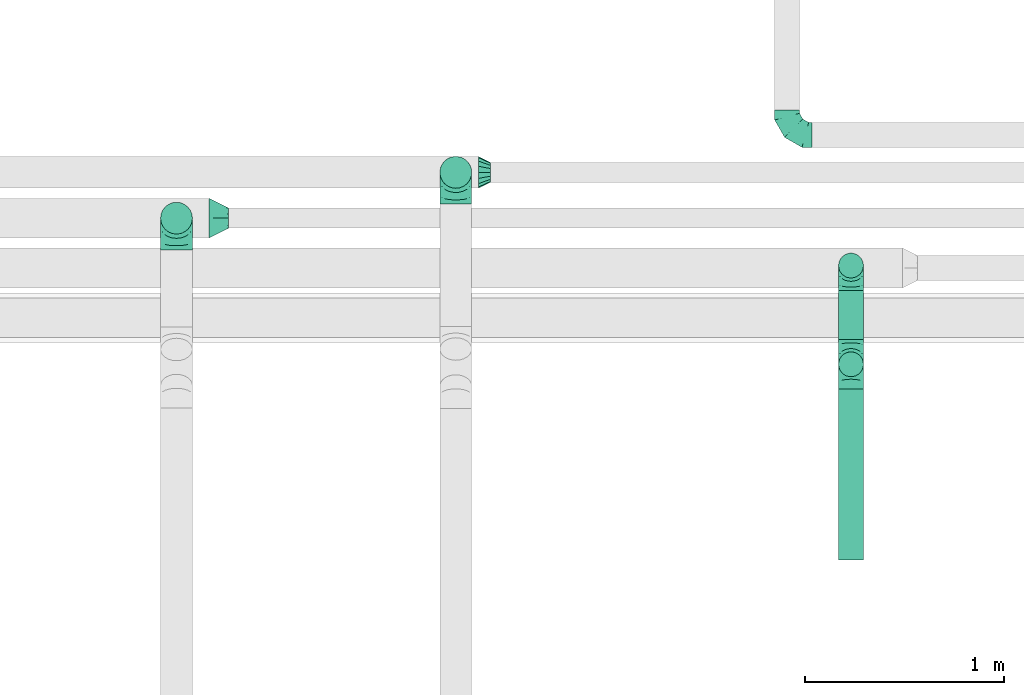
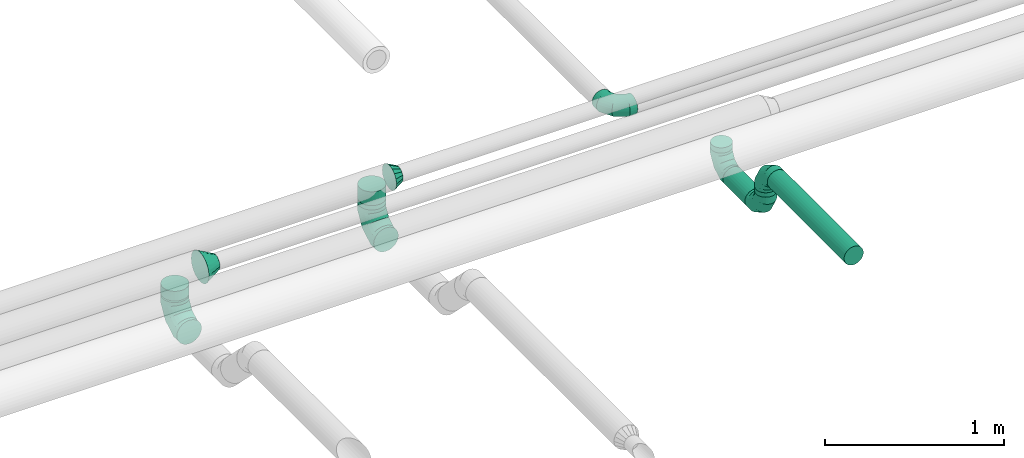
# One storey, part 52 of 92: 10 flow fittings, 5 flow segments.
"""IFC2X3 building model written with IfcOpenShell, lengths in millimetres."""

from ifc_helpers import new_model, entity, si_unit, converted_unit, derived_unit, direction, frame, origin, origin_2d_with_axis, place, context, subcontext, project, spatial, circle, extrude, faceted_brep, source, transform, mapped, material, type_object, type_shapes, element, save


model = new_model("IFC2X3")

# Units and contexts
model_context = context("Model", 3, precision=0.01, world=origin(), true_north=direction((6.12303176911189e-17, 1.0)))
body_context = subcontext(model_context, "Body", "Model", "MODEL_VIEW")
ifc_project = project(units=[si_unit("LENGTHUNIT", "METRE", prefix="MILLI"), si_unit("AREAUNIT", "SQUARE_METRE"), si_unit("VOLUMEUNIT", "CUBIC_METRE"), converted_unit("PLANEANGLEUNIT", "DEGREE", entity("IfcRatioMeasure", 0.0174532925199433), si_unit("PLANEANGLEUNIT", "RADIAN"), dimensions=[0, 0, 0, 0, 0, 0, 0]), si_unit("MASSUNIT", "GRAM", prefix="KILO"), derived_unit("MASSDENSITYUNIT", [(si_unit("MASSUNIT", "GRAM", prefix="KILO"), 1), (si_unit("LENGTHUNIT", "METRE"), -3)]), derived_unit("MOMENTOFINERTIAUNIT", [(si_unit("LENGTHUNIT", "METRE"), 4)]), si_unit("TIMEUNIT", "SECOND"), si_unit("FREQUENCYUNIT", "HERTZ"), si_unit("THERMODYNAMICTEMPERATUREUNIT", "DEGREE_CELSIUS"), derived_unit("THERMALTRANSMITTANCEUNIT", [(si_unit("MASSUNIT", "GRAM", prefix="KILO"), 1), (si_unit("THERMODYNAMICTEMPERATUREUNIT", "KELVIN"), -1), (si_unit("TIMEUNIT", "SECOND"), -3)]), derived_unit("VOLUMETRICFLOWRATEUNIT", [(si_unit("LENGTHUNIT", "METRE"), 3), (si_unit("TIMEUNIT", "SECOND"), -1)]), derived_unit("MASSFLOWRATEUNIT", [(si_unit("MASSUNIT", "GRAM", prefix="KILO"), 1), (si_unit("TIMEUNIT", "SECOND"), -1)]), derived_unit("ROTATIONALFREQUENCYUNIT", [(si_unit("TIMEUNIT", "SECOND"), -1)]), si_unit("ELECTRICCURRENTUNIT", "AMPERE"), si_unit("ELECTRICVOLTAGEUNIT", "VOLT"), si_unit("POWERUNIT", "WATT"), si_unit("FORCEUNIT", "NEWTON", prefix="KILO"), si_unit("ILLUMINANCEUNIT", "LUX"), si_unit("LUMINOUSFLUXUNIT", "LUMEN"), si_unit("LUMINOUSINTENSITYUNIT", "CANDELA"), derived_unit("USERDEFINED", [(si_unit("MASSUNIT", "GRAM", prefix="KILO"), -1), (si_unit("LENGTHUNIT", "METRE"), -2), (si_unit("TIMEUNIT", "SECOND"), 3), (si_unit("LUMINOUSFLUXUNIT", "LUMEN"), 1)]), derived_unit("LINEARVELOCITYUNIT", [(si_unit("LENGTHUNIT", "METRE"), 1), (si_unit("TIMEUNIT", "SECOND"), -1)]), si_unit("PRESSUREUNIT", "PASCAL"), derived_unit("USERDEFINED", [(si_unit("LENGTHUNIT", "METRE"), -2), (si_unit("MASSUNIT", "GRAM", prefix="KILO"), 1), (si_unit("TIMEUNIT", "SECOND"), -2)]), derived_unit("LINEARFORCEUNIT", [(si_unit("MASSUNIT", "GRAM", prefix="KILO"), 1), (si_unit("LENGTHUNIT", "METRE"), 1), (si_unit("TIMEUNIT", "SECOND"), -2), (si_unit("LENGTHUNIT", "METRE"), -1)]), derived_unit("PLANARFORCEUNIT", [(si_unit("MASSUNIT", "GRAM", prefix="KILO"), 1), (si_unit("LENGTHUNIT", "METRE"), 1), (si_unit("TIMEUNIT", "SECOND"), -2), (si_unit("LENGTHUNIT", "METRE"), -2)])], contexts=[model_context])

# Site, building, storey
site_placement = place(None, origin())
site = spatial("IfcSite", under=ifc_project, at=site_placement, CompositionType="ELEMENT")
building_placement = place(site_placement, origin())
building = spatial("IfcBuilding", under=site, at=building_placement, CompositionType="ELEMENT")
storey_placement = place(building_placement, frame((0.0, 0.0, 4200.0)))
storey = spatial("IfcBuildingStorey", under=building, at=storey_placement, CompositionType="ELEMENT", Elevation=4200.0)

# Flow segments
duct_segment_type = type_object("IfcDuctSegmentType", PredefinedType="NOTDEFINED")
flow_segment_1_placement = place(storey_placement, frame((44875.73, 4807.04, 3285.9)))
element("IfcFlowSegment", 1, at=flow_segment_1_placement, inside=storey, type_object=duct_segment_type, context=body_context, shape_type="SweptSolid", body=[
    extrude(circle(Radius=62.5, at=origin_2d_with_axis()), frame((64.1, 0.0, 64.1), z_axis=(0.0, 1.0, 0.0), x_axis=(-1.0, 0.0, 0.0)), (0.0, 0.0, 1.0), 858.438177938198),
])
flow_segment_2_placement = place(storey_placement, frame((42872.64, 6673.44, 3230.0)))
element("IfcFlowSegment", 2, at=flow_segment_2_placement, inside=storey, type_object=duct_segment_type, context=body_context, shape_type="SweptSolid", body=[
    extrude(circle(Radius=80.0, at=origin_2d_with_axis()), frame((81.6, 81.6, 0.0)), (0.0, 0.0, 1.0), 29.999999999991),
])
flow_segment_3_placement = place(storey_placement, frame((44875.73, 5915.48, 3005.9)))
element("IfcFlowSegment", 3, at=flow_segment_3_placement, inside=storey, type_object=duct_segment_type, context=body_context, shape_type="SweptSolid", body=[
    extrude(circle(Radius=62.5, at=origin_2d_with_axis()), frame((64.1, 0.0, 64.1), z_axis=(0.0, 1.0, 0.0), x_axis=(-1.0, 0.0, 0.0)), (0.0, 0.0, 1.0), 246.131881758027),
])
flow_segment_4_placement = place(storey_placement, frame((44875.73, 5726.39, 3195.0)))
element("IfcFlowSegment", 4, at=flow_segment_4_placement, inside=storey, type_object=duct_segment_type, context=body_context, shape_type="SweptSolid", body=[
    extrude(circle(Radius=62.5, at=origin_2d_with_axis()), frame((64.1, 64.1, 0.0)), (0.0, 0.0, 1.0), 30.000000000017),
])
flow_segment_5_placement = place(storey_placement, frame((44875.73, 6222.52, 3195.0)))
element("IfcFlowSegment", 5, at=flow_segment_5_placement, inside=storey, type_object=duct_segment_type, context=body_context, shape_type="SweptSolid", body=[
    extrude(circle(Radius=62.5, at=origin_2d_with_axis()), frame((64.1, 64.1, 0.0)), (0.0, 0.0, 1.0), 35.6986404926801),
])

# Flow fittings
ifc_material = material()
duct_fitting_type_1 = type_object("IfcDuctFittingType", PredefinedType="NOTDEFINED", material=ifc_material)
shared_shape_1 = source(origin(), body_context, "Body", "Brep", [
    faceted_brep([(-160.0, 0.0, -80.0), (-160.0, -20.71, -77.27), (-160.0, -40.0, -69.28), (-160.0, -56.57, -56.57), (-160.0, -69.28, -40.0), (-160.0, -77.27, -20.71), (-160.0, -80.0, 0.0), (-160.0, -77.27, 20.71), (-160.0, -69.28, 40.0), (-160.0, -56.57, 56.57), (-160.0, -40.0, 69.28), (-160.0, -20.71, 77.27), (-160.0, 0.0, 80.0), (-160.0, 20.71, 77.27), (-160.0, 40.0, 69.28), (-160.0, 56.57, 56.57), (-160.0, 69.28, 40.0), (-160.0, 77.27, 20.71), (-160.0, 80.0, 0.0), (-160.0, 77.27, -20.71), (-160.0, 69.28, -40.0), (-160.0, 56.57, -56.57), (-160.0, 40.0, -69.28), (-160.0, 20.71, -77.27), (-122.68, 20.71, 77.27), (-127.85, 40.0, 69.28), (-117.13, 0.0, 80.0), (-132.29, 56.57, 56.57), (-137.83, 77.27, 20.71), (-138.56, 80.0, 0.0), (-135.69, 69.28, 40.0), (-135.69, 69.28, -40.0), (-132.29, 56.57, -56.57), (-137.83, 77.27, -20.71), (-122.68, 20.71, -77.27), (-117.13, 0.0, -80.0), (-127.85, 40.0, -69.28), (-111.58, -20.71, -77.27), (-106.41, -40.0, -69.28), (-101.97, -56.57, -56.57), (-98.56, -69.28, -40.0), (-96.42, -77.27, -20.71), (-95.69, -80.0, 0.0), (-96.42, -77.27, 20.71), (-98.56, -69.28, 40.0), (-101.97, -56.57, 56.57), (-106.41, -40.0, 69.28), (-111.58, -20.71, 77.27), (-58.03, 58.03, 77.27), (-72.15, 72.15, 69.28), (-42.87, 42.87, 80.0), (-84.28, 84.28, 56.57), (-93.59, 93.59, 40.0), (-99.44, 99.44, 20.71), (-101.44, 101.44, 0.0), (-99.44, 99.44, -20.71), (-93.59, 93.59, -40.0), (-84.28, 84.28, -56.57), (-58.03, 58.03, -77.27), (-42.87, 42.87, -80.0), (-72.15, 72.15, -69.28), (-27.71, 27.71, -77.27), (-13.59, 13.59, -69.28), (-1.46, 1.46, -56.57), (7.85, -7.85, -40.0), (13.7, -13.7, -20.71), (15.69, -15.69, 0.0), (13.7, -13.7, 20.71), (7.85, -7.85, 40.0), (-1.46, 1.46, 56.57), (-13.59, 13.59, 69.28), (-27.71, 27.71, 77.27), (-20.71, 122.68, 77.27), (-40.0, 127.85, 69.28), (0.0, 117.13, 80.0), (-56.57, 132.29, 56.57), (-69.28, 135.69, 40.0), (-77.27, 137.83, 20.71), (-80.0, 138.56, 0.0), (-77.27, 137.83, -20.71), (-69.28, 135.69, -40.0), (-56.57, 132.29, -56.57), (-20.71, 122.68, -77.27), (0.0, 117.13, -80.0), (-40.0, 127.85, -69.28), (20.71, 111.58, -77.27), (40.0, 106.41, -69.28), (56.57, 101.97, -56.57), (69.28, 98.56, -40.0), (77.27, 96.42, -20.71), (80.0, 95.69, 0.0), (77.27, 96.42, 20.71), (69.28, 98.56, 40.0), (56.57, 101.97, 56.57), (40.0, 106.41, 69.28), (20.71, 111.58, 77.27), (-20.71, 160.0, -77.27), (-40.0, 160.0, -69.28), (-56.57, 160.0, -56.57), (-69.28, 160.0, -40.0), (-77.27, 160.0, -20.71), (-80.0, 160.0, 0.0), (-77.27, 160.0, 20.71), (-69.28, 160.0, 40.0), (-56.57, 160.0, 56.57), (-40.0, 160.0, 69.28), (-20.71, 160.0, 77.27), (0.0, 160.0, 80.0), (20.71, 160.0, 77.27), (40.0, 160.0, 69.28), (56.57, 160.0, 56.57), (69.28, 160.0, 40.0), (77.27, 160.0, 20.71), (80.0, 160.0, 0.0), (77.27, 160.0, -20.71), (69.28, 160.0, -40.0), (56.57, 160.0, -56.57), (40.0, 160.0, -69.28), (20.71, 160.0, -77.27), (0.0, 160.0, -80.0)], [[[0, 1, 2, 3, 4, 5, 6, 7, 8, 9, 10, 11, 12, 13, 14, 15, 16, 17, 18, 19, 20, 21, 22, 23]], [[24, 25, 14, 13]], [[26, 24, 13, 12]], [[14, 25, 27, 15]], [[28, 29, 18, 17]], [[30, 28, 17, 16]], [[15, 27, 30, 16]], [[20, 31, 32, 21]], [[33, 31, 20, 19]], [[18, 29, 33, 19]], [[34, 35, 0, 23]], [[36, 34, 23, 22]], [[32, 36, 22, 21]], [[1, 0, 35, 37]], [[2, 1, 37, 38]], [[3, 2, 38, 39]], [[5, 4, 40, 41]], [[6, 5, 41, 42]], [[39, 40, 4, 3]], [[6, 42, 43, 7]], [[7, 43, 44, 8]], [[8, 44, 45, 9]], [[9, 45, 46, 10]], [[10, 46, 47, 11]], [[26, 12, 11, 47]], [[48, 49, 25, 24]], [[50, 48, 24, 26]], [[27, 25, 49, 51]], [[52, 53, 28, 30]], [[51, 52, 30, 27]], [[29, 28, 53, 54]], [[55, 56, 31, 33]], [[54, 55, 33, 29]], [[32, 31, 56, 57]], [[58, 59, 35, 34]], [[60, 58, 34, 36]], [[57, 60, 36, 32]], [[37, 35, 59, 61]], [[38, 37, 61, 62]], [[39, 38, 62, 63]], [[41, 40, 64, 65]], [[42, 41, 65, 66]], [[63, 64, 40, 39]], [[43, 42, 66, 67]], [[44, 43, 67, 68]], [[68, 69, 45, 44]], [[46, 45, 69, 70]], [[47, 46, 70, 71]], [[26, 47, 71, 50]], [[72, 73, 49, 48]], [[74, 72, 48, 50]], [[51, 49, 73, 75]], [[76, 77, 53, 52]], [[75, 76, 52, 51]], [[54, 53, 77, 78]], [[79, 80, 56, 55]], [[78, 79, 55, 54]], [[57, 56, 80, 81]], [[82, 83, 59, 58]], [[84, 82, 58, 60]], [[81, 84, 60, 57]], [[61, 59, 83, 85]], [[62, 61, 85, 86]], [[63, 62, 86, 87]], [[65, 64, 88, 89]], [[66, 65, 89, 90]], [[87, 88, 64, 63]], [[67, 66, 90, 91]], [[68, 67, 91, 92]], [[92, 93, 69, 68]], [[70, 69, 93, 94]], [[71, 70, 94, 95]], [[50, 71, 95, 74]], [[96, 97, 98, 99, 100, 101, 102, 103, 104, 105, 106, 107, 108, 109, 110, 111, 112, 113, 114, 115, 116, 117, 118, 119]], [[72, 74, 107, 106]], [[73, 72, 106, 105]], [[75, 73, 105, 104]], [[77, 76, 103, 102]], [[78, 77, 102, 101]], [[75, 104, 103, 76]], [[78, 101, 100, 79]], [[79, 100, 99, 80]], [[80, 99, 98, 81]], [[84, 97, 96, 82]], [[82, 96, 119, 83]], [[84, 81, 98, 97]], [[118, 117, 86, 85]], [[119, 118, 85, 83]], [[116, 87, 86, 117]], [[88, 115, 114, 89]], [[89, 114, 113, 90]], [[115, 88, 87, 116]], [[112, 111, 92, 91]], [[113, 112, 91, 90]], [[111, 110, 93, 92]], [[95, 94, 109, 108]], [[74, 95, 108, 107]], [[110, 109, 94, 93]]]),
])
type_shapes(duct_fitting_type_1, [shared_shape_1])
for number, where, z_axis, x_axis in (
    (6, (41550.83, 6524.85, 3070.0), (-1.0, 0.0, 0.0), (0.0, 0.0, -1.0)),
    (7, (42954.24, 6755.04, 3070.0), (-1.0, 0.0, 0.0), (0.0, 0.0, -1.0)),
):
    element("IfcFlowFitting", number, at=place(storey_placement, frame(where, z_axis=z_axis, x_axis=x_axis)), inside=storey, type_object=duct_fitting_type_1, material=ifc_material, context=body_context, shape_type="MappedRepresentation", body=[
        mapped(shared_shape_1, transform((0.0, 0.0, 0.0), scale=1.0)),
    ])
duct_fitting_type_2 = type_object("IfcDuctFittingType", PredefinedType="NOTDEFINED", material=ifc_material)
shared_shape_2 = source(origin(), body_context, "Body", "Brep", [
    faceted_brep([(-125.0, 0.0, -62.5), (-125.0, -16.18, -60.37), (-125.0, -31.25, -54.13), (-125.0, -44.19, -44.19), (-125.0, -54.13, -31.25), (-125.0, -60.37, -16.18), (-125.0, -62.5, 0.0), (-125.0, -60.37, 16.18), (-125.0, -54.13, 31.25), (-125.0, -44.19, 44.19), (-125.0, -31.25, 54.13), (-125.0, -16.18, 60.37), (-125.0, 0.0, 62.5), (-125.0, 16.18, 60.37), (-125.0, 31.25, 54.13), (-125.0, 44.19, 44.19), (-125.0, 54.13, 31.25), (-125.0, 60.37, 16.18), (-125.0, 62.5, 0.0), (-125.0, 60.37, -16.18), (-125.0, 54.13, -31.25), (-125.0, 44.19, -44.19), (-125.0, 31.25, -54.13), (-125.0, 16.18, -60.37), (-95.84, 16.18, 60.37), (-99.88, 31.25, 54.13), (-91.51, 0.0, 62.5), (-103.35, 44.19, 44.19), (-107.68, 60.37, 16.18), (-108.25, 62.5, 0.0), (-106.01, 54.13, 31.25), (-106.01, 54.13, -31.25), (-103.35, 44.19, -44.19), (-107.68, 60.37, -16.18), (-95.84, 16.18, -60.37), (-91.51, 0.0, -62.5), (-99.88, 31.25, -54.13), (-87.17, -16.18, -60.37), (-83.13, -31.25, -54.13), (-79.66, -44.19, -44.19), (-77.0, -54.13, -31.25), (-75.33, -60.37, -16.18), (-74.76, -62.5, 0.0), (-75.33, -60.37, 16.18), (-77.0, -54.13, 31.25), (-79.66, -44.19, 44.19), (-83.13, -31.25, 54.13), (-87.17, -16.18, 60.37), (-45.34, 45.34, 60.37), (-56.37, 56.37, 54.13), (-33.49, 33.49, 62.5), (-65.85, 65.85, 44.19), (-73.12, 73.12, 31.25), (-77.69, 77.69, 16.18), (-79.25, 79.25, 0.0), (-77.69, 77.69, -16.18), (-73.12, 73.12, -31.25), (-65.85, 65.85, -44.19), (-45.34, 45.34, -60.37), (-33.49, 33.49, -62.5), (-56.37, 56.37, -54.13), (-21.65, 21.65, -60.37), (-10.62, 10.62, -54.13), (-1.14, 1.14, -44.19), (6.13, -6.13, -31.25), (10.7, -10.7, -16.18), (12.26, -12.26, 0.0), (10.7, -10.7, 16.18), (6.13, -6.13, 31.25), (-1.14, 1.14, 44.19), (-10.62, 10.62, 54.13), (-21.65, 21.65, 60.37), (-16.18, 95.84, 60.37), (-31.25, 99.88, 54.13), (0.0, 91.51, 62.5), (-44.19, 103.35, 44.19), (-54.13, 106.01, 31.25), (-60.37, 107.68, 16.18), (-62.5, 108.25, 0.0), (-60.37, 107.68, -16.18), (-54.13, 106.01, -31.25), (-44.19, 103.35, -44.19), (-16.18, 95.84, -60.37), (0.0, 91.51, -62.5), (-31.25, 99.88, -54.13), (16.18, 87.17, -60.37), (31.25, 83.13, -54.13), (44.19, 79.66, -44.19), (54.13, 77.0, -31.25), (60.37, 75.33, -16.18), (62.5, 74.76, 0.0), (60.37, 75.33, 16.18), (54.13, 77.0, 31.25), (44.19, 79.66, 44.19), (31.25, 83.13, 54.13), (16.18, 87.17, 60.37), (-16.18, 125.0, -60.37), (-31.25, 125.0, -54.13), (-44.19, 125.0, -44.19), (-54.13, 125.0, -31.25), (-60.37, 125.0, -16.18), (-62.5, 125.0, 0.0), (-60.37, 125.0, 16.18), (-54.13, 125.0, 31.25), (-44.19, 125.0, 44.19), (-31.25, 125.0, 54.13), (-16.18, 125.0, 60.37), (0.0, 125.0, 62.5), (16.18, 125.0, 60.37), (31.25, 125.0, 54.13), (44.19, 125.0, 44.19), (54.13, 125.0, 31.25), (60.37, 125.0, 16.18), (62.5, 125.0, 0.0), (60.37, 125.0, -16.18), (54.13, 125.0, -31.25), (44.19, 125.0, -44.19), (31.25, 125.0, -54.13), (16.18, 125.0, -60.37), (0.0, 125.0, -62.5)], [[[0, 1, 2, 3, 4, 5, 6, 7, 8, 9, 10, 11, 12, 13, 14, 15, 16, 17, 18, 19, 20, 21, 22, 23]], [[24, 25, 14, 13]], [[26, 24, 13, 12]], [[14, 25, 27, 15]], [[28, 29, 18, 17]], [[30, 28, 17, 16]], [[15, 27, 30, 16]], [[20, 31, 32, 21]], [[33, 31, 20, 19]], [[18, 29, 33, 19]], [[34, 35, 0, 23]], [[36, 34, 23, 22]], [[21, 32, 36, 22]], [[1, 0, 35, 37]], [[2, 1, 37, 38]], [[38, 39, 3, 2]], [[5, 4, 40, 41]], [[6, 5, 41, 42]], [[39, 40, 4, 3]], [[6, 42, 43, 7]], [[7, 43, 44, 8]], [[45, 9, 8, 44]], [[9, 45, 46, 10]], [[10, 46, 47, 11]], [[26, 12, 11, 47]], [[48, 49, 25, 24]], [[50, 48, 24, 26]], [[27, 25, 49, 51]], [[52, 53, 28, 30]], [[51, 52, 30, 27]], [[29, 28, 53, 54]], [[55, 56, 31, 33]], [[54, 55, 33, 29]], [[57, 32, 31, 56]], [[58, 59, 35, 34]], [[60, 58, 34, 36]], [[57, 60, 36, 32]], [[37, 35, 59, 61]], [[38, 37, 61, 62]], [[39, 38, 62, 63]], [[41, 40, 64, 65]], [[42, 41, 65, 66]], [[63, 64, 40, 39]], [[43, 42, 66, 67]], [[44, 43, 67, 68]], [[68, 69, 45, 44]], [[46, 45, 69, 70]], [[47, 46, 70, 71]], [[26, 47, 71, 50]], [[72, 73, 49, 48]], [[74, 72, 48, 50]], [[51, 49, 73, 75]], [[76, 77, 53, 52]], [[75, 76, 52, 51]], [[54, 53, 77, 78]], [[79, 80, 56, 55]], [[78, 79, 55, 54]], [[81, 57, 56, 80]], [[82, 83, 59, 58]], [[84, 82, 58, 60]], [[81, 84, 60, 57]], [[61, 59, 83, 85]], [[62, 61, 85, 86]], [[63, 62, 86, 87]], [[65, 64, 88, 89]], [[66, 65, 89, 90]], [[87, 88, 64, 63]], [[67, 66, 90, 91]], [[68, 67, 91, 92]], [[92, 93, 69, 68]], [[70, 69, 93, 94]], [[71, 70, 94, 95]], [[50, 71, 95, 74]], [[96, 97, 98, 99, 100, 101, 102, 103, 104, 105, 106, 107, 108, 109, 110, 111, 112, 113, 114, 115, 116, 117, 118, 119]], [[72, 74, 107, 106]], [[73, 72, 106, 105]], [[75, 73, 105, 104]], [[77, 76, 103, 102]], [[78, 77, 102, 101]], [[75, 104, 103, 76]], [[78, 101, 100, 79]], [[79, 100, 99, 80]], [[80, 99, 98, 81]], [[96, 119, 83, 82]], [[97, 96, 82, 84]], [[84, 81, 98, 97]], [[83, 119, 118, 85]], [[85, 118, 117, 86]], [[116, 87, 86, 117]], [[88, 115, 114, 89]], [[89, 114, 113, 90]], [[115, 88, 87, 116]], [[91, 90, 113, 112]], [[92, 91, 112, 111]], [[111, 110, 93, 92]], [[95, 94, 109, 108]], [[74, 95, 108, 107]], [[110, 109, 94, 93]]]),
])
type_shapes(duct_fitting_type_2, [shared_shape_2])
for number, where, z_axis, x_axis in (
    (8, (44939.83, 5790.48, 3350.0), (-1.0, 0.0, 0.0), (0.0, 1.0, 0.0)),
    (9, (44939.83, 6286.61, 3070.0), (-1.0, 0.0, 0.0), (0.0, 0.0, -1.0)),
    (10, (44939.83, 5790.48, 3070.0), (1.0, 0.0, 0.0), (0.0, 0.0, -1.0)),
    (11, (44618.77, 6943.28, 3160.0), (0.0, 0.0, 1.0), (0.0, -1.0, 0.0)),
):
    element("IfcFlowFitting", number, at=place(storey_placement, frame(where, z_axis=z_axis, x_axis=x_axis)), inside=storey, type_object=duct_fitting_type_2, material=ifc_material, context=body_context, shape_type="MappedRepresentation", body=[
        mapped(shared_shape_2, transform((0.0, 0.0, 0.0), scale=1.0)),
    ])
duct_fitting_type_3 = type_object("IfcDuctFittingType", PredefinedType="NOTDEFINED", material=ifc_material)
shared_shape_3 = source(origin(), body_context, "Body", "Brep", [
    faceted_brep([(60.0, -46.19, 19.13), (60.0, -48.1, 9.57), (60.0, -50.0, 0.0), (60.0, -48.1, -9.57), (60.0, -46.19, -19.13), (60.0, -40.77, -27.24), (60.0, -35.36, -35.36), (60.0, -27.24, -40.77), (60.0, -19.13, -46.19), (60.0, -9.57, -48.1), (60.0, 0.0, -50.0), (60.0, 9.57, -48.1), (60.0, 19.13, -46.19), (60.0, 27.24, -40.77), (60.0, 35.36, -35.36), (60.0, 40.77, -27.24), (60.0, 46.19, -19.13), (60.0, 48.1, -9.57), (60.0, 50.0, 0.0), (60.0, 48.1, 9.57), (60.0, 46.19, 19.13), (60.0, 40.77, 27.24), (60.0, 35.36, 35.36), (60.0, 27.24, 40.77), (60.0, 19.13, 46.19), (60.0, 9.57, 48.1), (60.0, 0.0, 50.0), (60.0, -9.57, 48.1), (60.0, -19.13, 46.19), (60.0, -27.24, 40.77), (60.0, -35.36, 35.36), (60.0, -40.77, 27.24), (0.0, -80.0, 0.0), (0.0, -77.16, 14.27), (0.0, -73.91, 30.61), (0.0, -65.24, 43.59), (0.0, -56.57, 56.57), (0.0, -43.59, 65.24), (0.0, -30.61, 73.91), (0.0, -15.31, 76.96), (0.0, 0.0, 80.0), (0.0, 14.27, 77.16), (0.0, 30.61, 73.91), (0.0, 43.59, 65.24), (0.0, 56.57, 56.57), (0.0, 65.24, 43.59), (0.0, 73.91, 30.61), (0.0, 76.96, 15.31), (0.0, 80.0, 0.0), (0.0, 77.16, -14.27), (0.0, 73.91, -30.61), (0.0, 65.24, -43.59), (0.0, 56.57, -56.57), (0.0, 43.59, -65.24), (0.0, 30.61, -73.91), (0.0, 15.31, -76.96), (0.0, 0.0, -80.0), (0.0, -14.27, -77.16), (0.0, -30.61, -73.91), (0.0, -43.59, -65.24), (0.0, -56.57, -56.57), (0.0, -65.24, -43.59), (0.0, -73.91, -30.61), (0.0, -76.96, -15.31)], [[[0, 1, 2, 3, 4, 5, 6, 7, 8, 9, 10, 11, 12, 13, 14, 15, 16, 17, 18, 19, 20, 21, 22, 23, 24, 25, 26, 27, 28, 29, 30, 31]], [[32, 33, 34, 35, 36, 37, 38, 39, 40, 41, 42, 43, 44, 45, 46, 47, 48, 49, 50, 51, 52, 53, 54, 55, 56, 57, 58, 59, 60, 61, 62, 63]], [[42, 41, 40, 26, 25, 24]], [[43, 42, 24, 23, 22, 44]], [[20, 46, 45, 44, 22, 21]], [[18, 48, 47, 46, 20, 19]], [[34, 33, 32, 2, 1, 0]], [[35, 34, 0, 31, 30, 36]], [[28, 38, 37, 36, 30, 29]], [[26, 40, 39, 38, 28, 27]], [[58, 57, 56, 10, 9, 8]], [[59, 58, 8, 7, 6, 60]], [[4, 62, 61, 60, 6, 5]], [[2, 32, 63, 62, 4, 3]], [[50, 49, 48, 18, 17, 16]], [[51, 50, 16, 15, 14, 52]], [[12, 54, 53, 52, 14, 13]], [[10, 56, 55, 54, 12, 11]]]),
])
type_shapes(duct_fitting_type_3, [shared_shape_3])
flow_fitting_1_placement = place(storey_placement, frame((43067.77, 6755.04, 3360.0)))
element("IfcFlowFitting", 12, at=flow_fitting_1_placement, inside=storey, type_object=duct_fitting_type_3, material=ifc_material, context=body_context, shape_type="MappedRepresentation", body=[
    mapped(shared_shape_3, transform((0.0, 0.0, 0.0), scale=1.0)),
])
duct_fitting_type_4 = type_object("IfcDuctFittingType", PredefinedType="NOTDEFINED", material=ifc_material)
shared_shape_4 = source(origin(), body_context, "Body", "Brep", [
    faceted_brep([(20.0, 0.0, -80.0), (20.0, 20.71, -77.27), (20.0, 40.0, -69.28), (20.0, 56.57, -56.57), (20.0, 69.28, -40.0), (20.0, 77.27, -20.71), (20.0, 80.0, 0.0), (20.0, 77.27, 20.71), (20.0, 69.28, 40.0), (20.0, 56.57, 56.57), (20.0, 40.0, 69.28), (20.0, 20.71, 77.27), (20.0, 0.0, 80.0), (20.0, -20.71, 77.27), (20.0, -40.0, 69.28), (20.0, -56.57, 56.57), (20.0, -69.28, 40.0), (20.0, -77.27, 20.71), (20.0, -80.0, 0.0), (20.0, -77.27, -20.71), (20.0, -69.28, -40.0), (20.0, -56.57, -56.57), (20.0, -40.0, -69.28), (20.0, -20.71, -77.27), (0.0, 0.0, 80.0), (-46.1, 0.0, 80.0), (-46.1, -20.71, 77.27), (0.0, -20.71, 77.27), (-46.1, -40.0, 69.28), (0.0, -40.0, 69.28), (0.0, -56.57, 56.57), (-46.1, -56.57, 56.57), (0.0, -69.28, 40.0), (-46.1, -69.28, 40.0), (-46.1, -77.27, 20.71), (0.0, -77.27, 20.71), (-46.1, -80.0, 0.0), (0.0, -80.0, 0.0), (-46.1, -77.27, -20.71), (0.0, -77.27, -20.71), (-46.1, -69.28, -40.0), (0.0, -69.28, -40.0), (0.0, -56.57, -56.57), (-46.1, -56.57, -56.57), (0.0, -40.0, -69.28), (-46.1, -40.0, -69.28), (-46.1, -20.71, -77.27), (0.0, -20.71, -77.27), (-46.1, 0.0, -80.0), (0.0, 0.0, -80.0), (-46.1, 20.71, -77.27), (0.0, 20.71, -77.27), (-46.1, 40.0, -69.28), (0.0, 40.0, -69.28), (0.0, 56.57, -56.57), (-46.1, 56.57, -56.57), (0.0, 69.28, -40.0), (-46.1, 69.28, -40.0), (-46.1, 77.27, -20.71), (0.0, 77.27, -20.71), (-46.1, 80.0, 0.0), (0.0, 80.0, 0.0), (-46.1, 77.27, 20.71), (0.0, 77.27, 20.71), (-46.1, 69.28, 40.0), (0.0, 69.28, 40.0), (0.0, 56.57, 56.57), (-46.1, 56.57, 56.57), (0.0, 40.0, 69.28), (-46.1, 40.0, 69.28), (-46.1, 20.71, 77.27), (0.0, 20.71, 77.27)], [[[0, 1, 2, 3, 4, 5, 6, 7, 8, 9, 10, 11, 12, 13, 14, 15, 16, 17, 18, 19, 20, 21, 22, 23]], [[13, 12, 24, 25, 26, 27]], [[14, 13, 27, 26, 28, 29]], [[30, 15, 14, 29, 28, 31]], [[17, 16, 32, 33, 34, 35]], [[18, 17, 35, 34, 36, 37]], [[32, 16, 15, 30, 31, 33]], [[19, 18, 37, 36, 38, 39]], [[20, 19, 39, 38, 40, 41]], [[42, 21, 20, 41, 40, 43]], [[23, 22, 44, 45, 46, 47]], [[0, 23, 47, 46, 48, 49]], [[44, 22, 21, 42, 43, 45]], [[1, 0, 49, 48, 50, 51]], [[2, 1, 51, 50, 52, 53]], [[54, 3, 2, 53, 52, 55]], [[5, 4, 56, 57, 58, 59]], [[6, 5, 59, 58, 60, 61]], [[56, 4, 3, 54, 55, 57]], [[7, 6, 61, 60, 62, 63]], [[8, 7, 63, 62, 64, 65]], [[66, 9, 8, 65, 64, 67]], [[11, 10, 68, 69, 70, 71]], [[12, 11, 71, 70, 25, 24]], [[68, 10, 9, 66, 67, 69]], [[46, 45, 43, 40, 38, 36, 34, 33, 31, 28, 26, 25, 70, 69, 67, 64, 62, 60, 58, 57, 55, 52, 50, 48]]]),
])
type_shapes(duct_fitting_type_4, [shared_shape_4])
flow_fitting_2_placement = place(storey_placement, frame((41550.83, 6524.85, 3260.0), z_axis=(0.0, -1.0, 0.0), x_axis=(0.0, 0.0, -1.0)))
element("IfcFlowFitting", 13, at=flow_fitting_2_placement, inside=storey, type_object=duct_fitting_type_4, material=ifc_material, context=body_context, shape_type="MappedRepresentation", body=[
    mapped(shared_shape_4, transform((0.0, 0.0, 0.0), scale=1.0)),
])
duct_fitting_type_5 = type_object("IfcDuctFittingType", PredefinedType="NOTDEFINED", material=ifc_material)
shared_shape_5 = source(origin(), body_context, "Body", "Brep", [
    faceted_brep([(20.0, 20.71, -77.27), (20.0, 40.0, -69.28), (20.0, 56.57, -56.57), (20.0, 69.28, -40.0), (20.0, 77.27, -20.71), (20.0, 80.0, 0.0), (20.0, 77.27, 20.71), (20.0, 69.28, 40.0), (20.0, 56.57, 56.57), (20.0, 40.0, 69.28), (20.0, 20.71, 77.27), (20.0, 0.0, 80.0), (20.0, -20.71, 77.27), (20.0, -40.0, 69.28), (20.0, -56.57, 56.57), (20.0, -69.28, 40.0), (20.0, -77.27, 20.71), (20.0, -80.0, 0.0), (20.0, -77.27, -20.71), (20.0, -69.28, -40.0), (20.0, -56.57, -56.57), (20.0, -40.0, -69.28), (20.0, -20.71, -77.27), (20.0, 0.0, -80.0), (0.0, 0.0, 80.0), (0.0, 20.71, 77.27), (-73.9, 20.71, 77.27), (-73.9, 0.0, 80.0), (0.0, 40.0, 69.28), (-73.9, 40.0, 69.28), (0.0, 56.57, 56.57), (-73.9, 56.57, 56.57), (0.0, 69.28, 40.0), (0.0, 77.27, 20.71), (-73.9, 77.27, 20.71), (-73.9, 69.28, 40.0), (0.0, 80.0, 0.0), (-73.9, 80.0, 0.0), (0.0, 77.27, -20.71), (-73.9, 77.27, -20.71), (0.0, 69.28, -40.0), (-73.9, 69.28, -40.0), (0.0, 56.57, -56.57), (-73.9, 56.57, -56.57), (0.0, 40.0, -69.28), (0.0, 20.71, -77.27), (-73.9, 20.71, -77.27), (-73.9, 40.0, -69.28), (0.0, 0.0, -80.0), (-73.9, 0.0, -80.0), (0.0, -20.71, -77.27), (-73.9, -20.71, -77.27), (0.0, -40.0, -69.28), (-73.9, -40.0, -69.28), (0.0, -56.57, -56.57), (-73.9, -56.57, -56.57), (0.0, -69.28, -40.0), (0.0, -77.27, -20.71), (-73.9, -77.27, -20.71), (-73.9, -69.28, -40.0), (0.0, -80.0, 0.0), (-73.9, -80.0, 0.0), (0.0, -77.27, 20.71), (-73.9, -77.27, 20.71), (0.0, -69.28, 40.0), (-73.9, -69.28, 40.0), (0.0, -56.57, 56.57), (-73.9, -56.57, 56.57), (0.0, -40.0, 69.28), (0.0, -20.71, 77.27), (-73.9, -20.71, 77.27), (-73.9, -40.0, 69.28)], [[[0, 1, 2, 3, 4, 5, 6, 7, 8, 9, 10, 11, 12, 13, 14, 15, 16, 17, 18, 19, 20, 21, 22, 23]], [[24, 11, 10, 25, 26, 27]], [[25, 10, 9, 28, 29, 26]], [[28, 9, 8, 30, 31, 29]], [[32, 7, 6, 33, 34, 35]], [[33, 6, 5, 36, 37, 34]], [[30, 8, 7, 32, 35, 31]], [[36, 5, 4, 38, 39, 37]], [[38, 4, 3, 40, 41, 39]], [[40, 3, 2, 42, 43, 41]], [[44, 1, 0, 45, 46, 47]], [[45, 0, 23, 48, 49, 46]], [[42, 2, 1, 44, 47, 43]], [[48, 23, 22, 50, 51, 49]], [[50, 22, 21, 52, 53, 51]], [[52, 21, 20, 54, 55, 53]], [[56, 19, 18, 57, 58, 59]], [[57, 18, 17, 60, 61, 58]], [[54, 20, 19, 56, 59, 55]], [[60, 17, 16, 62, 63, 61]], [[62, 16, 15, 64, 65, 63]], [[64, 15, 14, 66, 67, 65]], [[68, 13, 12, 69, 70, 71]], [[69, 12, 11, 24, 27, 70]], [[66, 14, 13, 68, 71, 67]], [[49, 51, 53, 55, 59, 58, 61, 63, 65, 67, 71, 70, 27, 26, 29, 31, 35, 34, 37, 39, 41, 43, 47, 46]]]),
])
type_shapes(duct_fitting_type_5, [shared_shape_5])
flow_fitting_3_placement = place(storey_placement, frame((42954.24, 6755.04, 3280.0), z_axis=(0.0, -1.0, 0.0), x_axis=(0.0, 0.0, -1.0)))
element("IfcFlowFitting", 14, at=flow_fitting_3_placement, inside=storey, type_object=duct_fitting_type_5, material=ifc_material, context=body_context, shape_type="MappedRepresentation", body=[
    mapped(shared_shape_5, transform((0.0, 0.0, 0.0), scale=1.0)),
])
duct_fitting_type_6 = type_object("IfcDuctFittingType", PredefinedType="NOTDEFINED", material=ifc_material)
shared_shape_6 = source(origin(), body_context, "Body", "Brep", [
    faceted_brep([(100.0, -46.19, 19.13), (100.0, -48.1, 9.57), (100.0, -50.0, 0.0), (100.0, -48.1, -9.57), (100.0, -46.19, -19.13), (100.0, -40.77, -27.24), (100.0, -35.36, -35.36), (100.0, -27.24, -40.77), (100.0, -19.13, -46.19), (100.0, -9.57, -48.1), (100.0, 0.0, -50.0), (100.0, 9.57, -48.1), (100.0, 19.13, -46.19), (100.0, 27.24, -40.77), (100.0, 35.36, -35.36), (100.0, 40.77, -27.24), (100.0, 46.19, -19.13), (100.0, 48.1, -9.57), (100.0, 50.0, 0.0), (100.0, 48.1, 9.57), (100.0, 46.19, 19.13), (100.0, 40.77, 27.24), (100.0, 35.36, 35.36), (100.0, 27.24, 40.77), (100.0, 19.13, 46.19), (100.0, 9.57, 48.1), (100.0, 0.0, 50.0), (100.0, -9.57, 48.1), (100.0, -19.13, 46.19), (100.0, -27.24, 40.77), (100.0, -35.36, 35.36), (100.0, -40.77, 27.24), (0.0, -100.0, 0.0), (0.0, -95.11, 30.9), (0.0, -80.9, 58.78), (0.0, -58.78, 80.9), (0.0, -30.9, 95.11), (0.0, 0.0, 100.0), (0.0, 30.9, 95.11), (0.0, 58.78, 80.9), (0.0, 80.9, 58.78), (0.0, 95.11, 30.9), (0.0, 100.0, 0.0), (0.0, 95.11, -30.9), (0.0, 80.9, -58.78), (0.0, 58.78, -80.9), (0.0, 30.9, -95.11), (0.0, 0.0, -100.0), (0.0, -30.9, -95.11), (0.0, -58.78, -80.9), (0.0, -80.9, -58.78), (0.0, -95.11, -30.9)], [[[0, 1, 2, 3, 4, 5, 6, 7, 8, 9, 10, 11, 12, 13, 14, 15, 16, 17, 18, 19, 20, 21, 22, 23, 24, 25, 26, 27, 28, 29, 30, 31]], [[32, 33, 34, 35, 36, 37, 38, 39, 40, 41, 42, 43, 44, 45, 46, 47, 48, 49, 50, 51]], [[37, 25, 38]], [[24, 39, 38]], [[40, 22, 21, 20]], [[23, 22, 39, 24]], [[41, 20, 19]], [[18, 42, 19]], [[25, 37, 26]], [[40, 20, 41]], [[19, 42, 41]], [[25, 24, 38]], [[22, 40, 39]], [[32, 1, 33]], [[0, 34, 33]], [[35, 30, 29, 28]], [[31, 30, 34, 0]], [[36, 28, 27]], [[26, 37, 27]], [[1, 32, 2]], [[35, 28, 36]], [[27, 37, 36]], [[1, 0, 33]], [[30, 35, 34]], [[47, 9, 48]], [[8, 49, 48]], [[50, 6, 5, 4]], [[7, 6, 49, 8]], [[51, 4, 3]], [[2, 32, 3]], [[9, 47, 10]], [[50, 4, 51]], [[3, 32, 51]], [[9, 8, 48]], [[6, 50, 49]], [[42, 17, 43]], [[16, 44, 43]], [[45, 14, 13, 12]], [[15, 14, 44, 16]], [[46, 12, 11]], [[10, 47, 11]], [[17, 42, 18]], [[45, 12, 46]], [[11, 47, 46]], [[17, 16, 43]], [[14, 45, 44]]]),
])
type_shapes(duct_fitting_type_6, [shared_shape_6])
flow_fitting_4_placement = place(storey_placement, frame((41713.36, 6524.85, 3360.0)))
element("IfcFlowFitting", 15, at=flow_fitting_4_placement, inside=storey, type_object=duct_fitting_type_6, material=ifc_material, context=body_context, shape_type="MappedRepresentation", body=[
    mapped(shared_shape_6, transform((0.0, 0.0, 0.0), scale=1.0)),
])

save(model, "model.ifc")
